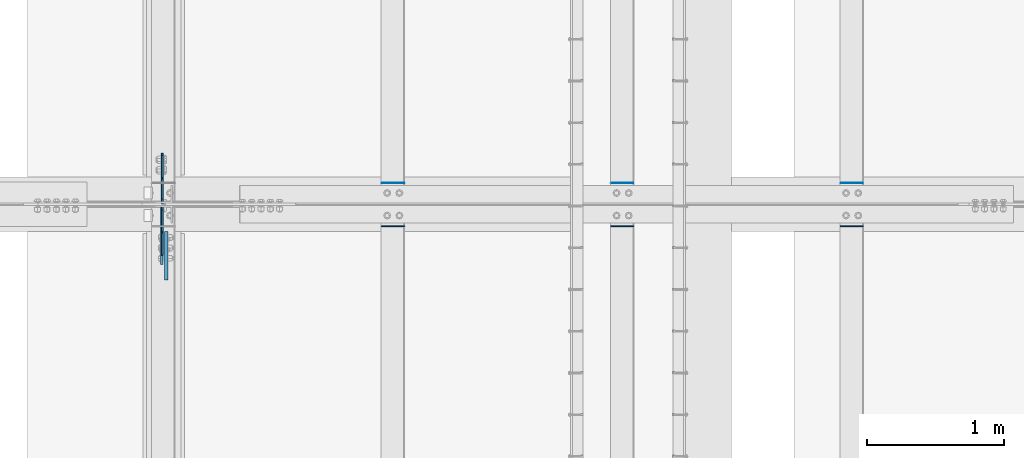
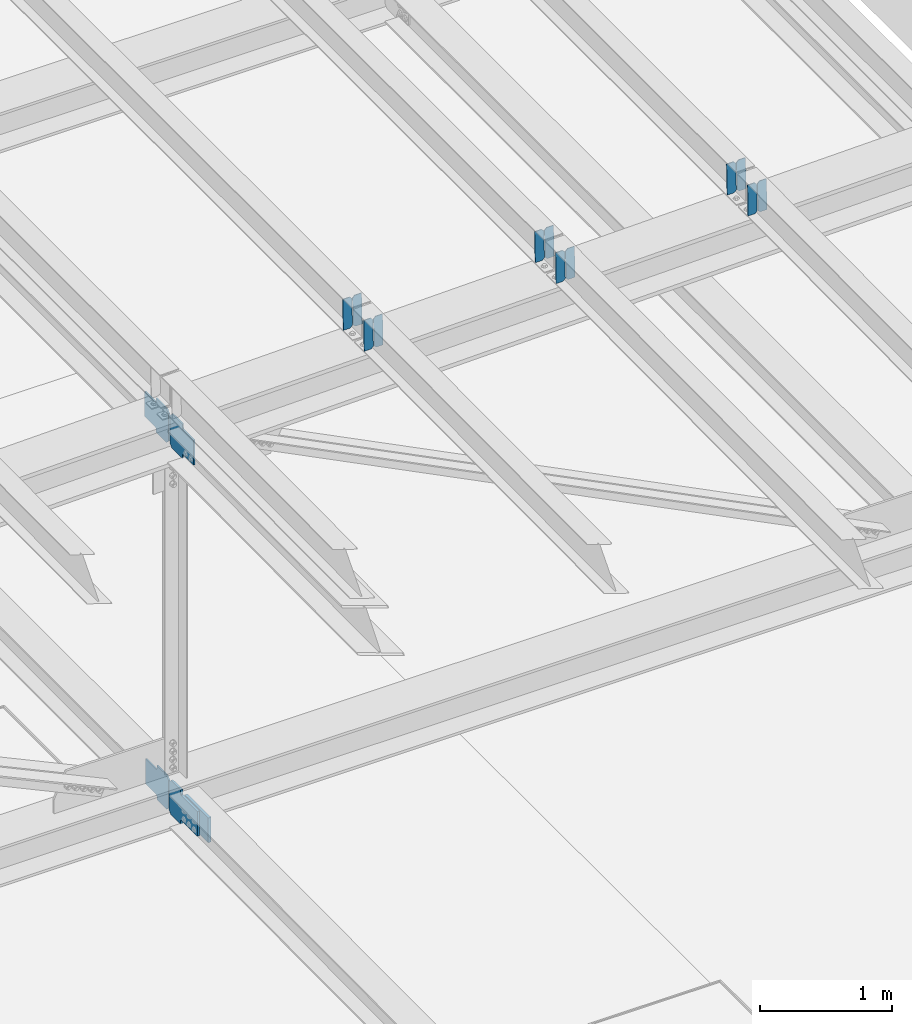
# One storey, part 3294 of 3843: 17 plates, 9 elements without a shape of their own.
"""IFC2X3 building model written with IfcOpenShell, lengths in millimetres."""

from ifc_helpers import new_model, si_unit, frame, origin_with_axes, place, context, subcontext, project, spatial, faceted_brep, material, type_object, element, aggregate, save


model = new_model("IFC2X3")

# Units and contexts
model_context = context("Model", 3, precision=1e-05, world=origin_with_axes())
body_context = subcontext(model_context, "Body", "Model", "MODEL_VIEW")
ifc_project = project(units=[si_unit("LENGTHUNIT", "METRE", prefix="MILLI"), si_unit("AREAUNIT", "SQUARE_METRE"), si_unit("VOLUMEUNIT", "CUBIC_METRE"), si_unit("MASSUNIT", "GRAM", prefix="KILO"), si_unit("TIMEUNIT", "SECOND"), si_unit("PLANEANGLEUNIT", "RADIAN"), si_unit("SOLIDANGLEUNIT", "STERADIAN"), si_unit("THERMODYNAMICTEMPERATUREUNIT", "DEGREE_CELSIUS"), si_unit("LUMINOUSINTENSITYUNIT", "LUMEN")], contexts=[model_context])

# Site, building, storey
site_placement = place(None, origin_with_axes())
site = spatial("IfcSite", under=ifc_project, at=site_placement, CompositionType="ELEMENT")
building_placement = place(site_placement, origin_with_axes())
building = spatial("IfcBuilding", under=site, at=building_placement, Name="Undefined", CompositionType="ELEMENT")
storey_placement = place(building_placement, origin_with_axes())
storey = spatial("IfcBuildingStorey", under=building, at=storey_placement, Name="Undefined", CompositionType="ELEMENT", Elevation=0.0)

# Assembly, plates
assembly_1_placement = place(storey_placement, origin_with_axes())
assembly_1 = element("IfcElementAssembly", 1, at=assembly_1_placement, inside=storey, Name="BEAM", AssemblyPlace="NOTDEFINED", PredefinedType="RIGID_FRAME")
ifc_material = material(Name="STEEL/A572-50")
plate_type_1 = type_object("IfcPlateType", PredefinedType="NOTDEFINED")
plate_1_placement = place(assembly_1_placement, frame((61042.2964782855, 42358.2133592432, 46024.6105959985), z_axis=(-0.0211520975395179, -0.00180653400038137, 0.999774637208098), x_axis=(-0.999776269352655, 3.88860000353947e-05, -0.0211520620074247)))
plate_1 = element("IfcPlate", 2, at=plate_1_placement, type_object=plate_type_1, material=ifc_material, Name="PLATE", context=body_context, shape_type="Brep", body=[
    faceted_brep([(0.0, -3.17499999999927, 0.0), (6.83940015733242e-10, -3.17499999996653, 288.924999998613), (6.54836185276508e-10, 3.17500000001746, 288.924999998591), (0.0, 3.17499999999927, 0.0), (60.3250007643655, -3.17500000017753, 288.924999998606), (60.3250007643219, 3.17499999979918, 288.924999998584), (79.3750000013097, -3.17500000025029, 269.875000761494), (79.375000001266, 3.17499999972642, 269.875000761487), (79.375000000713, -3.17500000026484, 19.0499992370605), (79.3750000006985, 3.17499999971187, 19.0499992370533), (60.325000763667, -3.17500000020664, -1.45519152283669e-11), (60.3250007636234, 3.17499999977736, -3.63797880709171e-11)], [[[0, 1, 2, 3]], [[1, 4, 5, 2]], [[4, 6, 7, 5]], [[6, 8, 9, 7]], [[8, 10, 11, 9]], [[10, 0, 3, 11]], [[5, 7, 9, 11, 3, 2]], [[10, 8, 6, 4, 1, 0]]]),
])
plate_2_placement = place(assembly_1_placement, frame((60956.5906575959, 42358.2166356977, 46022.7973353571), z_axis=(-0.0211520975395179, -0.00180653400038137, 0.999774637208098), x_axis=(-0.999776269352655, 3.88860000353947e-05, -0.0211520620074247)))
plate_2 = element("IfcPlate", 3, at=plate_2_placement, type_object=plate_type_1, material=ifc_material, Name="PLATE", context=body_context, shape_type="Brep", body=[
    faceted_brep([(4.36557456851006e-11, -3.17499999998836, 19.0499992370969), (6.11180439591408e-10, -3.17499999996653, 269.875000761516), (5.96628524363041e-10, 3.17500000001746, 269.875000761502), (1.45519152283669e-11, 3.17499999998836, 19.0499992370824), (19.0499992376572, -3.17500000003201, 288.924999998606), (19.0499992376281, 3.1749999999447, 288.924999998584), (79.3750000013242, -3.17500000025029, 288.924999998591), (79.3750000013097, 3.1749999997337, 288.92499999857), (79.3750000006548, -3.17500000026484, -2.18278728425503e-11), (79.3750000006403, 3.17499999969732, -2.91038304567337e-11), (19.0499992370023, -3.17500000005384, 0.0), (19.0499992369587, 3.17499999992287, -1.45519152283669e-11)], [[[0, 1, 2, 3]], [[1, 4, 5, 2]], [[4, 6, 7, 5]], [[6, 8, 9, 7]], [[8, 10, 11, 9]], [[10, 0, 3, 11]], [[5, 7, 9, 11, 3, 2]], [[10, 8, 6, 4, 1, 0]]]),
])
aggregate(assembly_1, [plate_1, plate_2])

assembly_2_placement = place(storey_placement, origin_with_axes())
assembly_2 = element("IfcElementAssembly", 4, at=assembly_2_placement, inside=storey, Name="BEAM", AssemblyPlace="NOTDEFINED", PredefinedType="RIGID_FRAME")
plate_3_placement = place(assembly_2_placement, frame((61042.296478274, 42042.5202182169, 46023.0791416592), z_axis=(-0.0211520976276079, -0.00782946099840774, 0.999745611796534), x_axis=(-0.99977626935452, 0.000165396000026019, -0.0211514510074668)))
plate_3 = element("IfcPlate", 5, at=plate_3_placement, type_object=plate_type_1, material=ifc_material, Name="PLATE", context=body_context, shape_type="Brep", body=[
    faceted_brep([(0.0, -3.17499999999927, 0.0), (6.83940015733242e-10, -3.17499999996653, 288.924999998613), (6.54836185276508e-10, 3.17500000001746, 288.924999998591), (0.0, 3.17499999999927, 0.0), (60.3250007643655, -3.17500000017753, 288.924999998606), (60.3250007643219, 3.17499999979918, 288.924999998584), (79.3750000013097, -3.17500000025029, 269.875000761494), (79.375000001266, 3.17499999972642, 269.875000761487), (79.375000000713, -3.17500000026484, 19.0499992370605), (79.3750000006985, 3.17499999971187, 19.0499992370533), (60.325000763667, -3.17500000020664, -1.45519152283669e-11), (60.3250007636234, 3.17499999977736, -3.63797880709171e-11)], [[[0, 1, 2, 3]], [[1, 4, 5, 2]], [[4, 6, 7, 5]], [[6, 8, 9, 7]], [[8, 10, 11, 9]], [[10, 0, 3, 11]], [[5, 7, 9, 11, 3, 2]], [[10, 8, 6, 4, 1, 0]]]),
])
plate_4_placement = place(assembly_2_placement, frame((60956.5906575847, 42042.5344182699, 46021.265933661), z_axis=(-0.0211520976276079, -0.00782946099840774, 0.999745611796534), x_axis=(-0.99977626935452, 0.000165396000026019, -0.0211514510074668)))
plate_4 = element("IfcPlate", 6, at=plate_4_placement, type_object=plate_type_1, material=ifc_material, Name="PLATE", context=body_context, shape_type="Brep", body=[
    faceted_brep([(4.36557456851006e-11, -3.17499999998836, 19.0499992370969), (6.11180439591408e-10, -3.17499999996653, 269.875000761516), (5.96628524363041e-10, 3.17500000001746, 269.875000761502), (1.45519152283669e-11, 3.17499999998836, 19.0499992370824), (19.0499992376572, -3.17500000003201, 288.924999998606), (19.0499992376281, 3.1749999999447, 288.924999998584), (79.3750000013242, -3.17500000025029, 288.924999998591), (79.3750000013097, 3.1749999997337, 288.92499999857), (79.3750000006548, -3.17500000026484, -2.18278728425503e-11), (79.3750000006403, 3.17499999969732, -2.91038304567337e-11), (19.0499992370023, -3.17500000005384, 0.0), (19.0499992369587, 3.17499999992287, -1.45519152283669e-11)], [[[0, 1, 2, 3]], [[1, 4, 5, 2]], [[4, 6, 7, 5]], [[6, 8, 9, 7]], [[8, 10, 11, 9]], [[10, 0, 3, 11]], [[5, 7, 9, 11, 3, 2]], [[10, 8, 6, 4, 1, 0]]]),
])
aggregate(assembly_2, [plate_3, plate_4])

assembly_3_placement = place(storey_placement, origin_with_axes())
assembly_3 = element("IfcElementAssembly", 7, at=assembly_3_placement, inside=storey, Name="BEAM", AssemblyPlace="NOTDEFINED", PredefinedType="RIGID_FRAME")
plate_5_placement = place(assembly_3_placement, frame((59365.8964782852, 42358.190720432, 45987.0370026205), z_axis=(-0.0211520976932152, -0.00173049699948751, 0.999774771707764), x_axis=(-0.99977626935114, 3.66869999923657e-05, -0.0211520660073878)))
plate_5 = element("IfcPlate", 8, at=plate_5_placement, type_object=plate_type_1, material=ifc_material, Name="PLATE", context=body_context, shape_type="Brep", body=[
    faceted_brep([(0.0, -3.17499999999927, 0.0), (6.83940015733242e-10, -3.17499999996653, 288.924999998613), (6.54836185276508e-10, 3.17500000001746, 288.924999998591), (0.0, 3.17499999999927, 0.0), (60.3250007643655, -3.17500000017753, 288.924999998606), (60.3250007643219, 3.17499999979918, 288.924999998584), (79.3750000013097, -3.17500000025029, 269.875000761494), (79.375000001266, 3.17499999972642, 269.875000761487), (79.375000000713, -3.17500000026484, 19.0499992370605), (79.3750000006985, 3.17499999971187, 19.0499992370533), (60.325000763667, -3.17500000020664, -1.45519152283669e-11), (60.3250007636234, 3.17499999977736, -3.63797880709171e-11)], [[[0, 1, 2, 3]], [[1, 4, 5, 2]], [[4, 6, 7, 5]], [[6, 8, 9, 7]], [[8, 10, 11, 9]], [[10, 0, 3, 11]], [[5, 7, 9, 11, 3, 2]], [[10, 8, 6, 4, 1, 0]]]),
])
plate_6_placement = place(assembly_3_placement, frame((59280.1906575955, 42358.1938589808, 45985.2237417364), z_axis=(-0.0211520976932152, -0.00173049699948751, 0.999774771707764), x_axis=(-0.99977626935114, 3.66869999923657e-05, -0.0211520660073878)))
plate_6 = element("IfcPlate", 9, at=plate_6_placement, type_object=plate_type_1, material=ifc_material, Name="PLATE", context=body_context, shape_type="Brep", body=[
    faceted_brep([(4.36557456851006e-11, -3.17499999998836, 19.0499992370969), (6.11180439591408e-10, -3.17499999996653, 269.875000761516), (5.96628524363041e-10, 3.17500000001746, 269.875000761502), (1.45519152283669e-11, 3.17499999998836, 19.0499992370824), (19.0499992376572, -3.17500000003201, 288.924999998606), (19.0499992376281, 3.1749999999447, 288.924999998584), (79.3750000013242, -3.17500000025029, 288.924999998591), (79.3750000013097, 3.1749999997337, 288.92499999857), (79.3750000006548, -3.17500000026484, -2.18278728425503e-11), (79.3750000006403, 3.17499999969732, -2.91038304567337e-11), (19.0499992370023, -3.17500000005384, 0.0), (19.0499992369587, 3.17499999992287, -1.45519152283669e-11)], [[[0, 1, 2, 3]], [[1, 4, 5, 2]], [[4, 6, 7, 5]], [[6, 8, 9, 7]], [[8, 10, 11, 9]], [[10, 0, 3, 11]], [[5, 7, 9, 11, 3, 2]], [[10, 8, 6, 4, 1, 0]]]),
])
aggregate(assembly_3, [plate_5, plate_6])

assembly_4_placement = place(storey_placement, origin_with_axes())
assembly_4 = element("IfcElementAssembly", 10, at=assembly_4_placement, inside=storey, Name="BEAM", AssemblyPlace="NOTDEFINED", PredefinedType="RIGID_FRAME")
plate_7_placement = place(assembly_4_placement, frame((59365.8964782774, 42042.4739668945, 45985.5416366706), z_axis=(-0.0211520983938898, -0.00767567500245056, 0.99974680431937), x_axis=(-0.999776269343847, 0.000161580000015114, -0.0211514810073172)))
plate_7 = element("IfcPlate", 11, at=plate_7_placement, type_object=plate_type_1, material=ifc_material, Name="PLATE", context=body_context, shape_type="Brep", body=[
    faceted_brep([(0.0, -3.17499999999927, 0.0), (6.83940015733242e-10, -3.17499999996653, 288.924999998613), (6.54836185276508e-10, 3.17500000001746, 288.924999998591), (0.0, 3.17499999999927, 0.0), (60.3250007643655, -3.17500000017753, 288.924999998606), (60.3250007643219, 3.17499999979918, 288.924999998584), (79.3750000013097, -3.17500000025029, 269.875000761494), (79.375000001266, 3.17499999972642, 269.875000761487), (79.375000000713, -3.17500000026484, 19.0499992370605), (79.3750000006985, 3.17499999971187, 19.0499992370533), (60.325000763667, -3.17500000020664, -1.45519152283669e-11), (60.3250007636234, 3.17499999977736, -3.63797880709171e-11)], [[[0, 1, 2, 3]], [[1, 4, 5, 2]], [[4, 6, 7, 5]], [[6, 8, 9, 7]], [[8, 10, 11, 9]], [[10, 0, 3, 11]], [[5, 7, 9, 11, 3, 2]], [[10, 8, 6, 4, 1, 0]]]),
])
plate_8_placement = place(assembly_4_placement, frame((59280.190657588, 42042.4878880302, 45983.7284265094), z_axis=(-0.0211520983938898, -0.00767567500245056, 0.99974680431937), x_axis=(-0.999776269343847, 0.000161580000015114, -0.0211514810073172)))
plate_8 = element("IfcPlate", 12, at=plate_8_placement, type_object=plate_type_1, material=ifc_material, Name="PLATE", context=body_context, shape_type="Brep", body=[
    faceted_brep([(4.36557456851006e-11, -3.17499999998836, 19.0499992370969), (6.11180439591408e-10, -3.17499999996653, 269.875000761516), (5.96628524363041e-10, 3.17500000001746, 269.875000761502), (1.45519152283669e-11, 3.17499999998836, 19.0499992370824), (19.0499992376572, -3.17500000003201, 288.924999998606), (19.0499992376281, 3.1749999999447, 288.924999998584), (79.3750000013242, -3.17500000025029, 288.924999998591), (79.3750000013097, 3.1749999997337, 288.92499999857), (79.3750000006548, -3.17500000026484, -2.18278728425503e-11), (79.3750000006403, 3.17499999969732, -2.91038304567337e-11), (19.0499992370023, -3.17500000005384, 0.0), (19.0499992369587, 3.17499999992287, -1.45519152283669e-11)], [[[0, 1, 2, 3]], [[1, 4, 5, 2]], [[4, 6, 7, 5]], [[6, 8, 9, 7]], [[8, 10, 11, 9]], [[10, 0, 3, 11]], [[5, 7, 9, 11, 3, 2]], [[10, 8, 6, 4, 1, 0]]]),
])
aggregate(assembly_4, [plate_7, plate_8])

assembly_5_placement = place(storey_placement, origin_with_axes())
assembly_5 = element("IfcElementAssembly", 13, at=assembly_5_placement, inside=storey, Name="BEAM", AssemblyPlace="NOTDEFINED", PredefinedType="RIGID_FRAME")
plate_9_placement = place(assembly_5_placement, frame((57689.4964782884, 42358.1660198176, 45948.9997842456), z_axis=(-0.0211520977282781, -0.00164754199975142, 0.999774911851189), x_axis=(-0.999776269344788, 3.44879999965181e-05, -0.0211520700073351)))
plate_9 = element("IfcPlate", 14, at=plate_9_placement, type_object=plate_type_1, material=ifc_material, Name="PLATE", context=body_context, shape_type="Brep", body=[
    faceted_brep([(0.0, -3.17499999999927, 0.0), (6.83940015733242e-10, -3.17499999996653, 288.924999998613), (6.54836185276508e-10, 3.17500000001746, 288.924999998591), (0.0, 3.17499999999927, 0.0), (60.3250007643655, -3.17500000017753, 288.924999998606), (60.3250007643219, 3.17499999979918, 288.924999998584), (79.3750000013097, -3.17500000025029, 269.875000761494), (79.375000001266, 3.17499999972642, 269.875000761487), (79.375000000713, -3.17500000026484, 19.0499992370605), (79.3750000006985, 3.17499999971187, 19.0499992370533), (60.325000763667, -3.17500000020664, -1.45519152283669e-11), (60.3250007636234, 3.17499999977736, -3.63797880709171e-11)], [[[0, 1, 2, 3]], [[1, 4, 5, 2]], [[4, 6, 7, 5]], [[6, 8, 9, 7]], [[8, 10, 11, 9]], [[10, 0, 3, 11]], [[5, 7, 9, 11, 3, 2]], [[10, 8, 6, 4, 1, 0]]]),
])
plate_10_placement = place(assembly_5_placement, frame((57603.7906575987, 42358.1690079129, 45947.1865231068), z_axis=(-0.0211520977282781, -0.00164754199975142, 0.999774911851189), x_axis=(-0.999776269344788, 3.44879999965181e-05, -0.0211520700073351)))
plate_10 = element("IfcPlate", 15, at=plate_10_placement, type_object=plate_type_1, material=ifc_material, Name="PLATE", context=body_context, shape_type="Brep", body=[
    faceted_brep([(4.36557456851006e-11, -3.17499999998836, 19.0499992370969), (6.11180439591408e-10, -3.17499999996653, 269.875000761516), (5.96628524363041e-10, 3.17500000001746, 269.875000761502), (1.45519152283669e-11, 3.17499999998836, 19.0499992370824), (19.0499992376572, -3.17500000003201, 288.924999998606), (19.0499992376281, 3.1749999999447, 288.924999998584), (79.3750000013242, -3.17500000025029, 288.924999998591), (79.3750000013097, 3.1749999997337, 288.92499999857), (79.3750000006548, -3.17500000026484, -2.18278728425503e-11), (79.3750000006403, 3.17499999969732, -2.91038304567337e-11), (19.0499992370023, -3.17500000005384, 0.0), (19.0499992369587, 3.17499999992287, -1.45519152283669e-11)], [[[0, 1, 2, 3]], [[1, 4, 5, 2]], [[4, 6, 7, 5]], [[6, 8, 9, 7]], [[8, 10, 11, 9]], [[10, 0, 3, 11]], [[5, 7, 9, 11, 3, 2]], [[10, 8, 6, 4, 1, 0]]]),
])
aggregate(assembly_5, [plate_9, plate_10])

assembly_6_placement = place(storey_placement, origin_with_axes())
assembly_6 = element("IfcElementAssembly", 16, at=assembly_6_placement, inside=storey, Name="BEAM", AssemblyPlace="NOTDEFINED", PredefinedType="RIGID_FRAME")
plate_11_placement = place(assembly_6_placement, frame((57689.4964782757, 42042.4110854063, 45947.5503156032), z_axis=(-0.0211520978910194, -0.00746655400006421, 0.999748388008789), x_axis=(-0.999776269349703, 0.000157969000045321, -0.0211515080073777)))
plate_11 = element("IfcPlate", 17, at=plate_11_placement, type_object=plate_type_1, material=ifc_material, Name="PLATE", context=body_context, shape_type="Brep", body=[
    faceted_brep([(0.0, -3.17499999999927, 0.0), (6.83940015733242e-10, -3.17499999996653, 288.924999998613), (6.54836185276508e-10, 3.17500000001746, 288.924999998591), (0.0, 3.17499999999927, 0.0), (60.3250007643655, -3.17500000017753, 288.924999998606), (60.3250007643219, 3.17499999979918, 288.924999998584), (79.3750000013097, -3.17500000025029, 269.875000761494), (79.375000001266, 3.17499999972642, 269.875000761487), (79.375000000713, -3.17500000026484, 19.0499992370605), (79.3750000006985, 3.17499999971187, 19.0499992370533), (60.325000763667, -3.17500000020664, -1.45519152283669e-11), (60.3250007636234, 3.17499999977736, -3.63797880709171e-11)], [[[0, 1, 2, 3]], [[1, 4, 5, 2]], [[4, 6, 7, 5]], [[6, 8, 9, 7]], [[8, 10, 11, 9]], [[10, 0, 3, 11]], [[5, 7, 9, 11, 3, 2]], [[10, 8, 6, 4, 1, 0]]]),
])
plate_12_placement = place(assembly_6_placement, frame((57603.7906575863, 42042.4246272661, 45945.7371025703), z_axis=(-0.0211520978910194, -0.00746655400006421, 0.999748388008789), x_axis=(-0.999776269349703, 0.000157969000045321, -0.0211515080073777)))
plate_12 = element("IfcPlate", 18, at=plate_12_placement, type_object=plate_type_1, material=ifc_material, Name="PLATE", context=body_context, shape_type="Brep", body=[
    faceted_brep([(4.36557456851006e-11, -3.17499999998836, 19.0499992370969), (6.11180439591408e-10, -3.17499999996653, 269.875000761516), (5.96628524363041e-10, 3.17500000001746, 269.875000761502), (1.45519152283669e-11, 3.17499999998836, 19.0499992370824), (19.0499992376572, -3.17500000003201, 288.924999998606), (19.0499992376281, 3.1749999999447, 288.924999998584), (79.3750000013242, -3.17500000025029, 288.924999998591), (79.3750000013097, 3.1749999997337, 288.92499999857), (79.3750000006548, -3.17500000026484, -2.18278728425503e-11), (79.3750000006403, 3.17499999969732, -2.91038304567337e-11), (19.0499992370023, -3.17500000005384, 0.0), (19.0499992369587, 3.17499999992287, -1.45519152283669e-11)], [[[0, 1, 2, 3]], [[1, 4, 5, 2]], [[4, 6, 7, 5]], [[6, 8, 9, 7]], [[8, 10, 11, 9]], [[10, 0, 3, 11]], [[5, 7, 9, 11, 3, 2]], [[10, 8, 6, 4, 1, 0]]]),
])
aggregate(assembly_6, [plate_11, plate_12])

# Assembly, plate
assembly_7_placement = place(storey_placement, origin_with_axes())
assembly_7 = element("IfcElementAssembly", 19, at=assembly_7_placement, inside=storey, Name="BEAM", AssemblyPlace="NOTDEFINED", PredefinedType="RIGID_FRAME")
plate_type_2 = type_object("IfcPlateType", PredefinedType="NOTDEFINED")
plate_13_placement = place(assembly_7_placement, frame((55919.6874999843, 42209.24375, 42189.069976674), z_axis=(0.0, 0.707106781186548, 0.707106781186548), x_axis=(5.70000238222118e-08, 0.707106781186546, -0.707106781186546)))
plate_13 = element("IfcPlate", 20, at=plate_13_placement, type_object=plate_type_2, material=ifc_material, Name="PLATE", context=body_context, shape_type="Brep", body=[
    faceted_brep([(0.0, -6.3499999046162, 0.0), (-179.587971286601, -6.34999999999854, 179.587971286262), (-179.587971286601, 6.34999999999854, 179.587971286262), (7.27595761418343e-12, 6.3499999046162, 0.0), (-179.587971286412, -6.34999999999854, 224.489251891624), (-179.587971286412, 6.34999999999854, 224.489251891624), (-75.7537598849303, -6.34999999999854, 328.323463292232), (-75.7537598849303, 6.34999999999854, 328.323463292232), (-53.5938077484861, -6.34999999999854, 306.163511152343), (-53.5938077484861, 6.34999999999854, 306.163511152343), (-49.4736312803434, -6.34999999999854, 303.410497251869), (-49.4736312803434, 6.34999999999854, 303.410497251869), (-44.6135517623079, -6.34999999999854, 302.443767329285), (-44.6135517623079, 6.34999999999854, 302.443767329285), (-39.7534722442761, -6.34999999999854, 303.410497251869), (-39.7534722442761, 6.34999999999854, 303.410497251869), (-35.6332957761297, -6.34999999999854, 306.163511152343), (-35.6332957761297, 6.34999999999854, 306.163511152343), (76.6199058715356, -6.34999999999854, 418.416712800012), (76.6199058715356, 6.34999999999854, 418.416712800012), (238.264516050003, -6.34999999999854, 256.772102621544), (238.264516050003, 6.34999999999854, 256.772102621544), (126.011314402338, -6.34999999999854, 144.518900973875), (126.011314402338, 6.34999999999854, 144.518900973875), (123.258300501864, -6.34999999999854, 140.398724505736), (123.258300501864, 6.34999999999854, 140.398724505736), (122.29157057928, -6.34999999999854, 135.538644987697), (122.29157057928, 6.34999999999854, 135.538644987697), (123.258300501864, -6.34999999999854, 130.678565469658), (123.258300501864, 6.34999999999854, 130.678565469658), (126.011314402338, -6.34999999999854, 126.558389001519), (126.011314402338, 6.34999999999854, 126.558389001519), (148.735492004496, -6.35000000000582, 103.834211399357), (148.735492004496, 6.35000000000582, 103.834211399357), (44.9012806051323, -6.35000000000582, -1.45519152283669e-11), (44.9012806051323, 6.35000000000582, -1.45519152283669e-11)], [[[0, 1, 2, 3]], [[1, 4, 5, 2]], [[4, 6, 7, 5]], [[6, 8, 9, 7]], [[8, 10, 11, 9]], [[10, 12, 13, 11]], [[12, 14, 15, 13]], [[14, 16, 17, 15]], [[16, 18, 19, 17]], [[18, 20, 21, 19]], [[20, 22, 23, 21]], [[22, 24, 25, 23]], [[24, 26, 27, 25]], [[26, 28, 29, 27]], [[28, 30, 31, 29]], [[30, 32, 33, 31]], [[32, 34, 35, 33]], [[34, 0, 3, 35]], [[5, 7, 9, 11, 13, 15, 17, 19, 21, 23, 25, 27, 29, 31, 33, 35, 3, 2]], [[34, 32, 30, 28, 26, 24, 22, 20, 18, 16, 14, 12, 10, 8, 6, 4, 1, 0]]]),
])

# Assembly, plates
assembly_8_placement = place(storey_placement, origin_with_axes())
assembly_8 = element("IfcElementAssembly", 21, at=assembly_8_placement, inside=storey, Name="BEAM", AssemblyPlace="NOTDEFINED", PredefinedType="RIGID_FRAME")
plate_14_placement = place(assembly_8_placement, frame((55919.6874998443, 42213.2125, 45573.3461195152), z_axis=(0.0, 0.707106781186548, 0.707106781186548), x_axis=(5.70000238222118e-08, 0.707106781186546, -0.707106781186546)))
plate_14 = element("IfcPlate", 22, at=plate_14_placement, type_object=plate_type_2, material=ifc_material, Name="PLATE", context=body_context, shape_type="Brep", body=[
    faceted_brep([(0.0, -6.3499999046162, 0.0), (-179.457650562197, -6.34999999999854, 179.457650562188), (-179.457650562197, 6.34999999999854, 179.457650562188), (7.27595761418343e-12, 6.3499999046162, 0.0), (-179.457650562197, -6.34999999999854, 224.35893116732), (-179.457650562197, 6.34999999999854, 224.35893116732), (-68.326981064487, -6.34999999999854, 335.489600665031), (-68.326981064487, 6.34999999999854, 335.489600665031), (-46.4142999453161, -6.34999999999854, 313.576919545856), (-46.4142999453161, 6.34999999999854, 313.576919545856), (-42.294123477177, -6.34999999999854, 310.823905645389), (-42.294123477177, 6.34999999999854, 310.823905645389), (-37.4340439591415, -6.34999999999854, 309.857175722806), (-37.4340439591415, 6.34999999999854, 309.857175722806), (-32.573964441106, -6.34999999999854, 310.823905645389), (-32.573964441106, 6.34999999999854, 310.823905645389), (-28.4537879729633, -6.34999999999854, 313.576919545863), (-28.4537879729633, 6.34999999999854, 313.576919545863), (83.7994136746911, -6.34999999999854, 425.830121193518), (83.7994136746911, 6.34999999999854, 425.830121193518), (245.444023853159, -6.34999999999854, 264.18551101505), (245.444023853159, 6.34999999999854, 264.18551101505), (133.190822205504, -6.34999999999854, 151.932309367396), (133.190822205504, 6.34999999999854, 151.932309367396), (130.437808305031, -6.34999999999854, 147.812132899257), (130.437808305031, 6.34999999999854, 147.812132899257), (129.471078382447, -6.34999999999854, 142.952053381217), (129.471078382447, 6.34999999999854, 142.952053381217), (130.437808305023, -6.34999999999854, 138.091973863186), (130.437808305023, 6.34999999999854, 138.091973863186), (133.190822205504, -6.34999999999854, 133.971797395039), (133.190822205504, 6.34999999999854, 133.971797395039), (156.031950102829, -6.35000000000582, 111.130669497703), (156.031950102829, 6.35000000000582, 111.130669497703), (44.9012806051323, -6.35000000000582, -1.45519152283669e-11), (44.9012806051323, 6.35000000000582, -1.45519152283669e-11)], [[[0, 1, 2, 3]], [[1, 4, 5, 2]], [[4, 6, 7, 5]], [[6, 8, 9, 7]], [[8, 10, 11, 9]], [[10, 12, 13, 11]], [[12, 14, 15, 13]], [[14, 16, 17, 15]], [[16, 18, 19, 17]], [[18, 20, 21, 19]], [[20, 22, 23, 21]], [[22, 24, 25, 23]], [[24, 26, 27, 25]], [[26, 28, 29, 27]], [[28, 30, 31, 29]], [[30, 32, 33, 31]], [[32, 34, 35, 33]], [[34, 0, 3, 35]], [[5, 7, 9, 11, 13, 15, 17, 19, 21, 23, 25, 27, 29, 31, 33, 35, 3, 2]], [[34, 32, 30, 28, 26, 24, 22, 20, 18, 16, 14, 12, 10, 8, 6, 4, 1, 0]]]),
])
plate_15_placement = place(assembly_8_placement, frame((55919.6875706311, 42190.9874999734, 45573.346120192), z_axis=(0.0, -0.707106781186682, 0.707106781186413), x_axis=(0.0, -0.707106781186548, -0.707106781186548)))
plate_15 = element("IfcPlate", 23, at=plate_15_placement, type_object=plate_type_2, material=ifc_material, Name="PLATE", context=body_context, shape_type="Brep", body=[
    faceted_brep([(0.0, -6.3499999046162, 0.0), (-179.457650562197, -6.34999999999854, 179.457650562188), (-179.457650562197, 6.34999999999854, 179.457650562188), (7.27595761418343e-12, 6.3499999046162, 0.0), (-179.457650562197, -6.34999999999854, 224.35893116732), (-179.457650562197, 6.34999999999854, 224.35893116732), (-68.326981064487, -6.34999999999854, 335.489600665031), (-68.326981064487, 6.34999999999854, 335.489600665031), (-44.8210162969481, -6.34999999999854, 311.983635904533), (-44.8210162969481, 6.34999999999854, 311.983635904533), (-40.7008398287944, -6.34999999999854, 309.230622004063), (-40.7008398287944, 6.34999999999854, 309.230622004063), (-35.8407603107626, -6.34999999999854, 308.263892081476), (-35.8407603107626, 6.34999999999854, 308.263892081476), (-30.9806807927307, -6.34999999999854, 309.230622004063), (-30.9806807927307, 6.34999999999854, 309.230622004063), (-26.8605043245916, -6.34999999999854, 311.983635904533), (-26.8605043245916, 6.34999999999854, 311.983635904533), (85.3926973221824, -6.34999999999854, 424.2368375513), (85.3926973221824, 6.34999999999854, 424.2368375513), (247.03730750065, -6.34999999999854, 262.592227372829), (247.03730750065, 6.34999999999854, 262.592227372829), (134.784105853883, -6.34999999999854, 150.339025726062), (134.784105853883, 6.34999999999854, 150.339025726062), (132.031091953409, -6.34999999999854, 146.218849257916), (132.031091953409, 6.34999999999854, 146.218849257916), (131.064362030826, -6.34999999999854, 141.358769739884), (131.064362030826, 6.34999999999854, 141.358769739884), (132.031091953409, -6.34999999999854, 136.498690221848), (132.031091953409, 6.34999999999854, 136.498690221848), (134.784105853883, -6.34999999999854, 132.378513753706), (134.784105853883, 6.34999999999854, 132.378513753706), (156.031950102829, -6.35000000000582, 111.130669497703), (156.031950102829, 6.35000000000582, 111.130669497703), (44.9012806051323, -6.35000000000582, -1.45519152283669e-11), (44.9012806051323, 6.35000000000582, -1.45519152283669e-11)], [[[0, 1, 2, 3]], [[1, 4, 5, 2]], [[4, 6, 7, 5]], [[6, 8, 9, 7]], [[8, 10, 11, 9]], [[10, 12, 13, 11]], [[12, 14, 15, 13]], [[14, 16, 17, 15]], [[16, 18, 19, 17]], [[18, 20, 21, 19]], [[20, 22, 23, 21]], [[22, 24, 25, 23]], [[24, 26, 27, 25]], [[26, 28, 29, 27]], [[28, 30, 31, 29]], [[30, 32, 33, 31]], [[32, 34, 35, 33]], [[34, 0, 3, 35]], [[5, 7, 9, 11, 13, 15, 17, 19, 21, 23, 25, 27, 29, 31, 33, 35, 3, 2]], [[34, 32, 30, 28, 26, 24, 22, 20, 18, 16, 14, 12, 10, 8, 6, 4, 1, 0]]]),
])
aggregate(assembly_8, [plate_14, plate_15])

# Plate
plate_type_3 = type_object("IfcPlateType", PredefinedType="NOTDEFINED")
plate_16_placement = place(assembly_7_placement, frame((55916.5125625092, 42194.9562500095, 42189.0701629405), z_axis=(0.0, -0.707106781186682, 0.707106781186413), x_axis=(0.0, -0.707106781186548, -0.707106781186548)))
plate_16 = element("IfcPlate", 24, at=plate_16_placement, type_object=plate_type_3, material=ifc_material, Name="PLATE", context=body_context, shape_type="Brep", body=[
    faceted_brep([(0.0, -9.52500000000146, 0.0), (-179.57919278905, -9.52500000000146, 179.579192788719), (-179.57919278905, 9.52500000000146, 179.579192788719), (0.0, 9.52500000000146, 0.0), (-179.579192788857, -9.52500000000146, 224.480473394098), (-179.579192788857, 9.52500000000146, 224.480473394098), (-75.7449813875719, -9.52500000000146, 328.314684794474), (-75.7449813875719, 9.52500000000146, 328.314684794474), (-52.0896238180103, -9.52500000000146, 304.659327224959), (-52.0896238180103, 9.52500000000146, 304.659327224959), (-47.9694473498748, -9.52500000000146, 301.906313324507), (-47.9694473498748, 9.52500000000146, 301.906313324507), (-43.1093678318393, -9.52500000000146, 300.939583401938), (-43.1093678318393, 9.52500000000146, 300.939583401938), (-38.249288313782, -9.52500000000146, 301.906313324551), (-38.249288313782, 9.52500000000146, 301.906313324551), (-34.1291118456065, -9.52500000000146, 304.659327225032), (-34.1291118456065, 9.52500000000146, 304.659327225032), (136.495754590851, -9.52500000000146, 475.284193660031), (136.495754590851, 9.52500000000146, 475.284193660031), (298.140364770297, -9.52500000000146, 313.639583480865), (298.140364770297, 9.52500000000146, 313.639583480865), (127.515498333934, -9.52500000000146, 143.014717045968), (127.515498333934, 9.52500000000146, 143.014717045968), (124.762484433395, -9.52500000000146, 138.894540577778), (124.762484433395, 9.52500000000146, 138.894540577778), (123.795754510764, -9.52500000000146, 134.034461059695), (123.795754510764, 9.52500000000146, 134.034461059695), (124.762484433333, -9.52500000000146, 129.174381541627), (124.762484433333, 9.52500000000146, 129.174381541627), (127.515498333807, -9.52500000000146, 125.054205073466), (127.515498333807, 9.52500000000146, 125.054205073466), (148.735492003645, -9.52499999999418, 103.834211398527), (148.735492003645, 9.52499999999418, 103.834211398527), (44.9012806055835, -9.52499999999418, 4.65661287307739e-10), (44.9012806055835, 9.52499999999418, 4.65661287307739e-10)], [[[0, 1, 2, 3]], [[1, 4, 5, 2]], [[4, 6, 7, 5]], [[6, 8, 9, 7]], [[8, 10, 11, 9]], [[10, 12, 13, 11]], [[12, 14, 15, 13]], [[14, 16, 17, 15]], [[16, 18, 19, 17]], [[18, 20, 21, 19]], [[20, 22, 23, 21]], [[22, 24, 25, 23]], [[24, 26, 27, 25]], [[26, 28, 29, 27]], [[28, 30, 31, 29]], [[30, 32, 33, 31]], [[32, 34, 35, 33]], [[34, 0, 3, 35]], [[5, 7, 9, 11, 13, 15, 17, 19, 21, 23, 25, 27, 29, 31, 33, 35, 3, 2]], [[34, 32, 30, 28, 26, 24, 22, 20, 18, 16, 14, 12, 10, 8, 6, 4, 1, 0]]]),
])

aggregate(assembly_7, [plate_13, plate_16])

# Assembly, plate
assembly_9_placement = place(storey_placement, origin_with_axes())
assembly_9 = element("IfcElementAssembly", 25, at=assembly_9_placement, inside=storey, Name="BEAM", AssemblyPlace="NOTDEFINED", PredefinedType="RIGID_FRAME")
plate_type_4 = type_object("IfcPlateType", PredefinedType="NOTDEFINED")
plate_17_placement = place(assembly_9_placement, frame((55948.2626071349, 42003.6625001916, 42428.3580431752), z_axis=(0.0, 0.0, -1.0), x_axis=(0.0, -1.0, 0.0)))
plate_17 = element("IfcPlate", 26, at=plate_17_placement, type_object=plate_type_4, material=ifc_material, Name="PLATE", context=body_context, shape_type="Brep", body=[
    faceted_brep([(0.0, -12.6999999999971, 0.0), (1.30967237055302e-10, -12.6999999999971, 228.600000023711), (1.30967237055302e-10, 12.6999999999971, 228.600000023711), (0.0, 12.6999999999971, 0.0), (355.600000000137, -12.6999999999971, 228.600000023711), (355.600000000137, 12.6999999999971, 228.600000023711), (355.599999999999, -12.7000000000007, 0.0), (355.599999999999, 12.7000000000007, 0.0)], [[[0, 1, 2, 3]], [[1, 4, 5, 2]], [[4, 6, 7, 5]], [[6, 0, 3, 7]], [[5, 7, 3, 2]], [[6, 4, 1, 0]]]),
])
aggregate(assembly_9, [plate_17])

save(model, "model.ifc")
